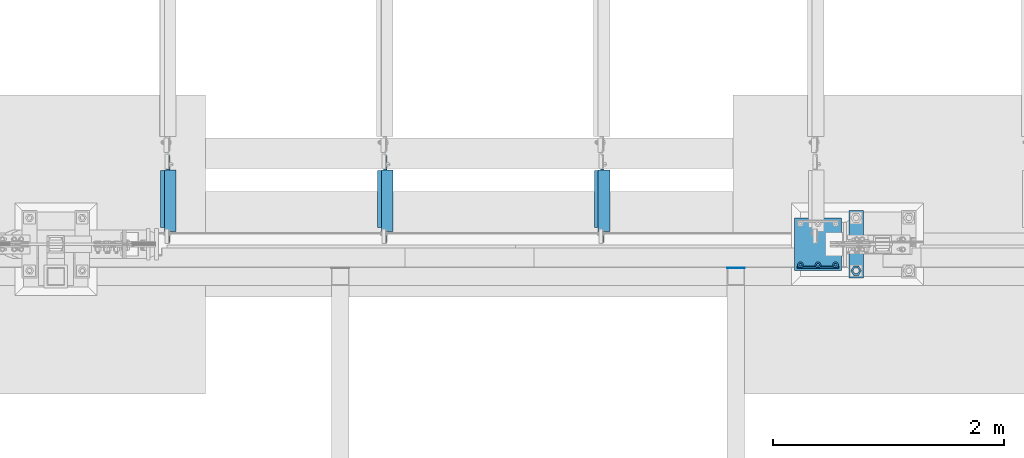
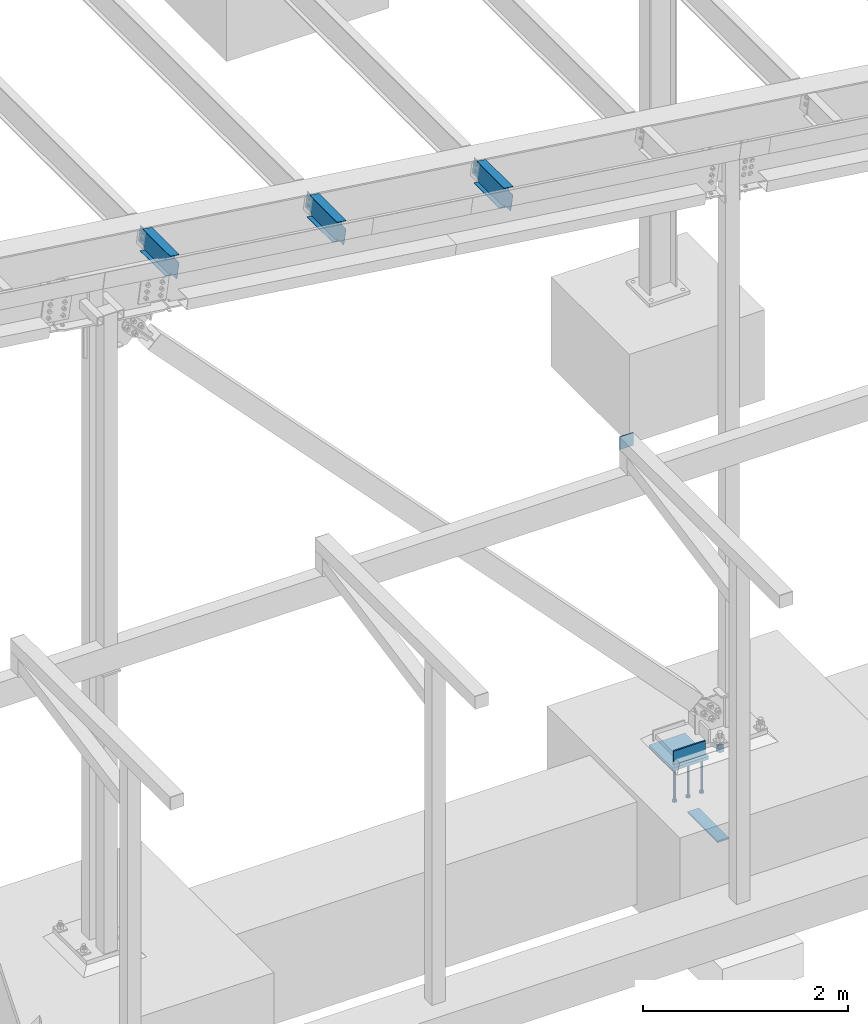
# One storey, part 849 of 1179: 11 beams, 7 elements without a shape of their own.
"""IFC2X3 building model written with IfcOpenShell, lengths in millimetres."""

from ifc_helpers import new_model, si_unit, frame, origin_with_axes, place, context, subcontext, project, spatial, faceted_brep, material, type_object, element, aggregate, save


model = new_model("IFC2X3")

# Units and contexts
model_context = context("Model", 3, precision=1e-05, world=origin_with_axes())
body_context = subcontext(model_context, "Body", "Model", "MODEL_VIEW")
ifc_project = project(units=[si_unit("LENGTHUNIT", "METRE", prefix="MILLI"), si_unit("AREAUNIT", "SQUARE_METRE"), si_unit("VOLUMEUNIT", "CUBIC_METRE"), si_unit("MASSUNIT", "GRAM", prefix="KILO"), si_unit("TIMEUNIT", "SECOND"), si_unit("PLANEANGLEUNIT", "RADIAN"), si_unit("SOLIDANGLEUNIT", "STERADIAN"), si_unit("THERMODYNAMICTEMPERATUREUNIT", "DEGREE_CELSIUS"), si_unit("LUMINOUSINTENSITYUNIT", "LUMEN")], contexts=[model_context])

# Site, building, storey
site_placement = place(None, origin_with_axes())
site = spatial("IfcSite", under=ifc_project, at=site_placement, CompositionType="ELEMENT")
building_placement = place(site_placement, origin_with_axes())
building = spatial("IfcBuilding", under=site, at=building_placement, Name="Undefined", CompositionType="ELEMENT")
storey_placement = place(building_placement, origin_with_axes())
storey = spatial("IfcBuildingStorey", under=building, at=storey_placement, Name="Undefined", CompositionType="ELEMENT", Elevation=0.0)

# Assembly, beam
assembly_1_placement = place(storey_placement, origin_with_axes())
assembly_1 = element("IfcElementAssembly", 1, at=assembly_1_placement, inside=storey, Name="BEAM", AssemblyPlace="NOTDEFINED", PredefinedType="RIGID_FRAME")
ifc_material_1 = material(Name="STEEL/A992")
beam_type_1 = type_object("IfcBeamType", Name="W10X12", PredefinedType="NOTDEFINED")
beam_1_placement = place(assembly_1_placement, frame((32495.2181490509, 4648.2, 6804.55819780635), z_axis=(0.133813223953133, 0.0, 0.991006569652931), x_axis=(0.0, 1.0, 0.0)))
beam_1 = element("IfcBeam", 2, at=beam_1_placement, type_object=beam_type_1, material=ifc_material_1, Name="BEAM", ObjectType="W10X12", context=body_context, shape_type="Brep", body=[
    faceted_brep([(641.349999999998, -2.38124999986758, -120.650000000041), (641.349999999998, -50.7999999998792, -120.650000000054), (641.349999999998, -50.7999999998719, -125.412500000057), (641.349999999998, 50.8000000001484, -125.412500000028), (641.349999999998, 50.8000000001412, -120.650000000027), (641.349999999998, 2.38125000012951, -120.650000000038), (641.349999999998, 2.38125000012224, -106.362499801333), (641.349999999998, -2.38124999988213, -106.362499801329), (642.316729922585, 2.38125000011496, -101.502420283283), (642.316729922585, -2.38124999988213, -101.502420283279), (645.069743823064, 2.38125000011496, -97.3822438151255), (645.069743823064, -2.38124999988941, -97.3822438151219), (649.189920291217, 2.38125000010768, -94.6292299146444), (649.189920291217, -2.38124999989668, -94.6292299146407), (654.049999809263, 2.38125000010768, -93.6624999920532), (654.049999809263, -2.38124999989668, -93.6624999920496), (768.349999999998, -2.38124999988941, -93.6624999919513), (768.349999999998, 2.38125000010768, -93.6624999919441), (109.537500000001, 2.38124999985303, 120.650000000041), (109.537500000001, 50.7999999998647, 120.650000000056), (642.937499999997, 50.7999999998647, 120.650000000056), (642.937499999997, 2.38124999985303, 120.650000000041), (144.462500000001, -2.38124999988213, -106.362499807816), (144.462500000001, 2.38125000011496, -106.362499807819), (144.462500000001, 2.38125000012951, -120.650000000038), (144.462500000001, 50.8000000001412, -120.650000000027), (144.462500000001, 50.8000000001484, -125.412500000028), (144.462500000001, -50.7999999998719, -125.412500000057), (144.462500000001, -50.7999999998792, -120.650000000054), (144.462500000001, -2.38124999986758, -120.650000000041), (143.495770077414, -2.38124999988213, -101.502420289766), (143.495770077414, 2.38125000011496, -101.502420289768), (140.742756176935, -2.38124999988941, -97.3822438216066), (140.742756176935, 2.38125000011496, -97.3822438216102), (136.622579708782, -2.38124999989668, -94.6292299211254), (136.622579708782, 2.38125000010768, -94.6292299211291), (131.762500190736, -2.38124999988941, -93.6624999985379), (131.762500190736, 2.38125000010768, -93.6624999985397), (17.4624999999996, -2.38124999988941, -93.662499998647), (17.4624999999996, 2.38125000010768, -93.6624999986416), (17.4624999999996, -2.38125000011496, 93.6625000015429), (17.4624999999996, 2.38124999988941, 93.6625000015483), (96.8375001907361, -2.38125000011496, 93.662500001652), (96.8375001907361, 2.38124999988941, 93.6625000016502), (101.697579708782, -2.38125000011496, 94.6292299242414), (101.697579708782, 2.38124999987485, 94.6292299242377), (105.817756176935, -2.38125000011496, 97.3822438247225), (105.817756176935, 2.38124999988213, 97.3822438247189), (108.570770077414, -2.38125000012224, 101.50242029288), (108.570770077414, 2.38124999987485, 101.502420292876), (109.537500000001, -2.38125000012951, 106.36249981093), (109.537500000001, 2.38124999986758, 106.362499810928), (109.537500000001, -50.800000000163, 125.412500000028), (109.537500000001, 50.7999999998574, 125.412500000059), (109.537500000001, -2.38125000014406, 120.650000000041), (109.537500000001, -50.8000000001557, 120.650000000027), (642.937499999997, -2.38125000014406, 120.650000000041), (642.937499999997, -50.8000000001557, 120.650000000027), (642.937499999997, -50.800000000163, 125.412500000028), (642.937499999997, 50.7999999998574, 125.412500000059), (642.937499999997, -2.38125000012224, 100.012499817411), (642.937499999997, 2.38124999987485, 100.012499817409), (643.904229922585, -2.38125000012224, 95.1524202993623), (643.904229922585, 2.38124999988213, 95.1524202993587), (646.657243823063, -2.38125000011496, 91.0322438312032), (646.657243823063, 2.38124999988941, 91.0322438311996), (650.777420291217, -2.38125000010768, 88.2792299307239), (650.777420291217, 2.38124999988941, 88.2792299307202), (655.637499809262, -2.38125000010768, 87.3125000081345), (655.637499809262, 2.38124999988941, 87.3125000081309), (768.349999999998, -2.38125000010768, 87.3125000082346), (768.349999999998, 2.38124999988941, 87.31250000824)], [[[0, 1, 2, 3, 4, 5, 6, 7]], [[7, 6, 8, 9]], [[9, 8, 10, 11]], [[11, 10, 12, 13]], [[13, 12, 14, 15]], [[16, 15, 14, 17]], [[18, 19, 20, 21]], [[22, 23, 24, 25, 26, 27, 28, 29]], [[30, 31, 23, 22]], [[32, 33, 31, 30]], [[34, 35, 33, 32]], [[36, 37, 35, 34]], [[38, 39, 37, 36]], [[40, 41, 39, 38]], [[42, 43, 41, 40]], [[44, 45, 43, 42]], [[46, 47, 45, 44]], [[48, 49, 47, 46]], [[50, 51, 49, 48]], [[52, 53, 19, 18, 51, 50, 54, 55]], [[55, 54, 56, 57]], [[52, 55, 57, 58]], [[53, 52, 58, 59]], [[19, 53, 59, 20]], [[58, 57, 56, 60, 61, 21, 20, 59]], [[62, 63, 61, 60]], [[64, 65, 63, 62]], [[66, 67, 65, 64]], [[68, 69, 67, 66]], [[70, 71, 69, 68]], [[71, 70, 16, 17]], [[12, 10, 8, 6, 5, 24, 23, 31, 33, 35, 37, 39, 41, 43, 45, 47, 49, 51, 18, 21, 61, 63, 65, 67, 69, 71, 17, 14]], [[25, 24, 5, 4]], [[26, 25, 4, 3]], [[27, 26, 3, 2]], [[28, 27, 2, 1]], [[29, 28, 1, 0]], [[70, 68, 66, 64, 62, 60, 56, 54, 50, 48, 46, 44, 42, 40, 38, 36, 34, 32, 30, 22, 29, 0, 7, 9, 11, 13, 15, 16]]]),
])
aggregate(assembly_1, [beam_1])

assembly_2_placement = place(storey_placement, origin_with_axes())
assembly_2 = element("IfcElementAssembly", 3, at=assembly_2_placement, inside=storey, Name="BEAM", AssemblyPlace="NOTDEFINED", PredefinedType="RIGID_FRAME")
beam_2_placement = place(assembly_2_placement, frame((30615.6181490507, 4648.2, 7058.35604682428), z_axis=(0.133813223953133, 0.0, 0.991006569652931), x_axis=(0.0, 1.0, 0.0)))
beam_2 = element("IfcBeam", 4, at=beam_2_placement, type_object=beam_type_1, material=ifc_material_1, Name="BEAM", ObjectType="W10X12", context=body_context, shape_type="Brep", body=[
    faceted_brep([(641.349999999998, -2.38124999986758, -120.650000000041), (641.349999999998, -50.7999999998792, -120.650000000054), (641.349999999998, -50.7999999998719, -125.412500000057), (641.349999999998, 50.8000000001484, -125.412500000028), (641.349999999998, 50.8000000001412, -120.650000000027), (641.349999999998, 2.38125000012951, -120.650000000038), (641.349999999998, 2.38125000012224, -106.362499801333), (641.349999999998, -2.38124999988213, -106.362499801329), (642.316729922585, 2.38125000011496, -101.502420283283), (642.316729922585, -2.38124999988213, -101.502420283279), (645.069743823064, 2.38125000011496, -97.3822438151255), (645.069743823064, -2.38124999988941, -97.3822438151219), (649.189920291217, 2.38125000010768, -94.6292299146444), (649.189920291217, -2.38124999989668, -94.6292299146407), (654.049999809263, 2.38125000010768, -93.6624999920532), (654.049999809263, -2.38124999989668, -93.6624999920496), (768.349999999998, -2.38124999988941, -93.6624999919513), (768.349999999998, 2.38125000010768, -93.6624999919441), (109.537500000001, 2.38124999985303, 120.650000000041), (109.537500000001, 50.7999999998647, 120.650000000056), (642.937499999997, 50.7999999998647, 120.650000000056), (642.937499999997, 2.38124999985303, 120.650000000041), (144.462500000001, -2.38124999988213, -106.362499807816), (144.462500000001, 2.38125000011496, -106.362499807819), (144.462500000001, 2.38125000012951, -120.650000000038), (144.462500000001, 50.8000000001412, -120.650000000027), (144.462500000001, 50.8000000001484, -125.412500000028), (144.462500000001, -50.7999999998719, -125.412500000057), (144.462500000001, -50.7999999998792, -120.650000000054), (144.462500000001, -2.38124999986758, -120.650000000041), (143.495770077414, -2.38124999988213, -101.502420289766), (143.495770077414, 2.38125000011496, -101.502420289768), (140.742756176935, -2.38124999988941, -97.3822438216066), (140.742756176935, 2.38125000011496, -97.3822438216102), (136.622579708782, -2.38124999989668, -94.6292299211254), (136.622579708782, 2.38125000010768, -94.6292299211291), (131.762500190736, -2.38124999988941, -93.6624999985379), (131.762500190736, 2.38125000010768, -93.6624999985397), (17.4624999999996, -2.38124999988941, -93.662499998647), (17.4624999999996, 2.38125000010768, -93.6624999986416), (17.4624999999996, -2.38125000011496, 93.6625000015429), (17.4624999999996, 2.38124999988941, 93.6625000015483), (96.8375001907361, -2.38125000011496, 93.662500001652), (96.8375001907361, 2.38124999988941, 93.6625000016502), (101.697579708782, -2.38125000011496, 94.6292299242414), (101.697579708782, 2.38124999987485, 94.6292299242377), (105.817756176935, -2.38125000011496, 97.3822438247225), (105.817756176935, 2.38124999988213, 97.3822438247189), (108.570770077414, -2.38125000012224, 101.50242029288), (108.570770077414, 2.38124999987485, 101.502420292876), (109.537500000001, -2.38125000012951, 106.36249981093), (109.537500000001, 2.38124999986758, 106.362499810928), (109.537500000001, -50.800000000163, 125.412500000028), (109.537500000001, 50.7999999998574, 125.412500000059), (109.537500000001, -2.38125000014406, 120.650000000041), (109.537500000001, -50.8000000001557, 120.650000000027), (642.937499999997, -2.38125000014406, 120.650000000041), (642.937499999997, -50.8000000001557, 120.650000000027), (642.937499999997, -50.800000000163, 125.412500000028), (642.937499999997, 50.7999999998574, 125.412500000059), (642.937499999997, -2.38125000012224, 100.012499817411), (642.937499999997, 2.38124999987485, 100.012499817409), (643.904229922585, -2.38125000012224, 95.1524202993623), (643.904229922585, 2.38124999988213, 95.1524202993587), (646.657243823063, -2.38125000011496, 91.0322438312032), (646.657243823063, 2.38124999988941, 91.0322438311996), (650.777420291217, -2.38125000010768, 88.2792299307239), (650.777420291217, 2.38124999988941, 88.2792299307202), (655.637499809262, -2.38125000010768, 87.3125000081345), (655.637499809262, 2.38124999988941, 87.3125000081309), (768.349999999998, -2.38125000010768, 87.3125000082346), (768.349999999998, 2.38124999988941, 87.31250000824)], [[[0, 1, 2, 3, 4, 5, 6, 7]], [[7, 6, 8, 9]], [[9, 8, 10, 11]], [[11, 10, 12, 13]], [[13, 12, 14, 15]], [[16, 15, 14, 17]], [[18, 19, 20, 21]], [[22, 23, 24, 25, 26, 27, 28, 29]], [[30, 31, 23, 22]], [[32, 33, 31, 30]], [[34, 35, 33, 32]], [[36, 37, 35, 34]], [[38, 39, 37, 36]], [[40, 41, 39, 38]], [[42, 43, 41, 40]], [[44, 45, 43, 42]], [[46, 47, 45, 44]], [[48, 49, 47, 46]], [[50, 51, 49, 48]], [[52, 53, 19, 18, 51, 50, 54, 55]], [[55, 54, 56, 57]], [[52, 55, 57, 58]], [[53, 52, 58, 59]], [[19, 53, 59, 20]], [[58, 57, 56, 60, 61, 21, 20, 59]], [[62, 63, 61, 60]], [[64, 65, 63, 62]], [[66, 67, 65, 64]], [[68, 69, 67, 66]], [[70, 71, 69, 68]], [[71, 70, 16, 17]], [[12, 10, 8, 6, 5, 24, 23, 31, 33, 35, 37, 39, 41, 43, 45, 47, 49, 51, 18, 21, 61, 63, 65, 67, 69, 71, 17, 14]], [[25, 24, 5, 4]], [[26, 25, 4, 3]], [[27, 26, 3, 2]], [[28, 27, 2, 1]], [[29, 28, 1, 0]], [[70, 68, 66, 64, 62, 60, 56, 54, 50, 48, 46, 44, 42, 40, 38, 36, 34, 32, 30, 22, 29, 0, 7, 9, 11, 13, 15, 16]]]),
])
aggregate(assembly_2, [beam_2])

assembly_3_placement = place(storey_placement, origin_with_axes())
assembly_3 = element("IfcElementAssembly", 5, at=assembly_3_placement, inside=storey, Name="BEAM", AssemblyPlace="NOTDEFINED", PredefinedType="RIGID_FRAME")
beam_3_placement = place(assembly_3_placement, frame((28736.0181490507, 4648.2, 7312.15389584228), z_axis=(0.133813223953133, 0.0, 0.991006569652931), x_axis=(0.0, 1.0, 0.0)))
beam_3 = element("IfcBeam", 6, at=beam_3_placement, type_object=beam_type_1, material=ifc_material_1, Name="BEAM", ObjectType="W10X12", context=body_context, shape_type="Brep", body=[
    faceted_brep([(641.349999999998, -2.38124999986758, -120.650000000041), (641.349999999998, -50.7999999998792, -120.650000000054), (641.349999999998, -50.7999999998719, -125.412500000057), (641.349999999998, 50.8000000001484, -125.412500000028), (641.349999999998, 50.8000000001412, -120.650000000027), (641.349999999998, 2.38125000012951, -120.650000000038), (641.349999999998, 2.38125000012224, -106.362499801333), (641.349999999998, -2.38124999988213, -106.362499801329), (642.316729922585, 2.38125000011496, -101.502420283283), (642.316729922585, -2.38124999988213, -101.502420283279), (645.069743823064, 2.38125000011496, -97.3822438151255), (645.069743823064, -2.38124999988941, -97.3822438151219), (649.189920291217, 2.38125000010768, -94.6292299146444), (649.189920291217, -2.38124999989668, -94.6292299146407), (654.049999809263, 2.38125000010768, -93.6624999920532), (654.049999809263, -2.38124999989668, -93.6624999920496), (768.349999999998, -2.38124999988941, -93.6624999919513), (768.349999999998, 2.38125000010768, -93.6624999919441), (109.537500000001, 2.38124999985303, 120.650000000041), (109.537500000001, 50.7999999998647, 120.650000000056), (642.937499999997, 50.7999999998647, 120.650000000056), (642.937499999997, 2.38124999985303, 120.650000000041), (144.462500000001, -2.38124999988213, -106.362499807816), (144.462500000001, 2.38125000011496, -106.362499807819), (144.462500000001, 2.38125000012951, -120.650000000038), (144.462500000001, 50.8000000001412, -120.650000000027), (144.462500000001, 50.8000000001484, -125.412500000028), (144.462500000001, -50.7999999998719, -125.412500000057), (144.462500000001, -50.7999999998792, -120.650000000054), (144.462500000001, -2.38124999986758, -120.650000000041), (143.495770077414, -2.38124999988213, -101.502420289766), (143.495770077414, 2.38125000011496, -101.502420289768), (140.742756176935, -2.38124999988941, -97.3822438216066), (140.742756176935, 2.38125000011496, -97.3822438216102), (136.622579708782, -2.38124999989668, -94.6292299211254), (136.622579708782, 2.38125000010768, -94.6292299211291), (131.762500190736, -2.38124999988941, -93.6624999985379), (131.762500190736, 2.38125000010768, -93.6624999985397), (17.4624999999996, -2.38124999988941, -93.662499998647), (17.4624999999996, 2.38125000010768, -93.6624999986416), (17.4624999999996, -2.38125000011496, 93.6625000015429), (17.4624999999996, 2.38124999988941, 93.6625000015483), (96.8375001907361, -2.38125000011496, 93.662500001652), (96.8375001907361, 2.38124999988941, 93.6625000016502), (101.697579708782, -2.38125000011496, 94.6292299242414), (101.697579708782, 2.38124999987485, 94.6292299242377), (105.817756176935, -2.38125000011496, 97.3822438247225), (105.817756176935, 2.38124999988213, 97.3822438247189), (108.570770077414, -2.38125000012224, 101.50242029288), (108.570770077414, 2.38124999987485, 101.502420292876), (109.537500000001, -2.38125000012951, 106.36249981093), (109.537500000001, 2.38124999986758, 106.362499810928), (109.537500000001, -50.800000000163, 125.412500000028), (109.537500000001, 50.7999999998574, 125.412500000059), (109.537500000001, -2.38125000014406, 120.650000000041), (109.537500000001, -50.8000000001557, 120.650000000027), (642.937499999997, -2.38125000014406, 120.650000000041), (642.937499999997, -50.8000000001557, 120.650000000027), (642.937499999997, -50.800000000163, 125.412500000028), (642.937499999997, 50.7999999998574, 125.412500000059), (642.937499999997, -2.38125000012224, 100.012499817411), (642.937499999997, 2.38124999987485, 100.012499817409), (643.904229922585, -2.38125000012224, 95.1524202993623), (643.904229922585, 2.38124999988213, 95.1524202993587), (646.657243823063, -2.38125000011496, 91.0322438312032), (646.657243823063, 2.38124999988941, 91.0322438311996), (650.777420291217, -2.38125000010768, 88.2792299307239), (650.777420291217, 2.38124999988941, 88.2792299307202), (655.637499809262, -2.38125000010768, 87.3125000081345), (655.637499809262, 2.38124999988941, 87.3125000081309), (768.349999999998, -2.38125000010768, 87.3125000082346), (768.349999999998, 2.38124999988941, 87.31250000824)], [[[0, 1, 2, 3, 4, 5, 6, 7]], [[7, 6, 8, 9]], [[9, 8, 10, 11]], [[11, 10, 12, 13]], [[13, 12, 14, 15]], [[16, 15, 14, 17]], [[18, 19, 20, 21]], [[22, 23, 24, 25, 26, 27, 28, 29]], [[30, 31, 23, 22]], [[32, 33, 31, 30]], [[34, 35, 33, 32]], [[36, 37, 35, 34]], [[38, 39, 37, 36]], [[40, 41, 39, 38]], [[42, 43, 41, 40]], [[44, 45, 43, 42]], [[46, 47, 45, 44]], [[48, 49, 47, 46]], [[50, 51, 49, 48]], [[52, 53, 19, 18, 51, 50, 54, 55]], [[55, 54, 56, 57]], [[52, 55, 57, 58]], [[53, 52, 58, 59]], [[19, 53, 59, 20]], [[58, 57, 56, 60, 61, 21, 20, 59]], [[62, 63, 61, 60]], [[64, 65, 63, 62]], [[66, 67, 65, 64]], [[68, 69, 67, 66]], [[70, 71, 69, 68]], [[71, 70, 16, 17]], [[12, 10, 8, 6, 5, 24, 23, 31, 33, 35, 37, 39, 41, 43, 45, 47, 49, 51, 18, 21, 61, 63, 65, 67, 69, 71, 17, 14]], [[25, 24, 5, 4]], [[26, 25, 4, 3]], [[27, 26, 3, 2]], [[28, 27, 2, 1]], [[29, 28, 1, 0]], [[70, 68, 66, 64, 62, 60, 56, 54, 50, 48, 46, 44, 42, 40, 38, 36, 34, 32, 30, 22, 29, 0, 7, 9, 11, 13, 15, 16]]]),
])
aggregate(assembly_3, [beam_3])

assembly_4_placement = place(storey_placement, origin_with_axes())
assembly_4 = element("IfcElementAssembly", 7, at=assembly_4_placement, inside=storey, Name="BEAM", AssemblyPlace="NOTDEFINED", PredefinedType="RIGID_FRAME")
ifc_material_2 = material(Name="STEEL/A36")
beam_type_2 = type_object("IfcBeamType", PredefinedType="NOTDEFINED")
beam_4_placement = place(assembly_4_placement, frame((33731.2, 4441.825, 3702.05), z_axis=(0.0, 0.0, -1.0), x_axis=(-1.0, 0.0, 0.0)))
beam_4 = element("IfcBeam", 8, at=beam_4_placement, type_object=beam_type_2, material=ifc_material_2, Name="PLATE", context=body_context, shape_type="Brep", body=[
    faceted_brep([(-1.47792889038101e-12, 3.17500000000018, -76.1999999999953), (1.36424205265939e-12, 3.17500000000018, 76.1999999999953), (152.399999999989, 3.17500000000018, 76.200000000028), (152.399999999986, 3.17500000000018, -76.1999999999625), (1.36424205265939e-12, -3.17500000000018, 76.1999999999953), (152.399999999989, -3.17500000000018, 76.200000000028), (-1.47792889038101e-12, -3.17500000000018, -76.1999999999953), (152.399999999986, -3.17500000000018, -76.1999999999625)], [[[0, 1, 2, 3]], [[1, 4, 5, 2]], [[4, 6, 7, 5]], [[6, 0, 3, 7]], [[5, 7, 3, 2]], [[6, 4, 1, 0]]]),
])
aggregate(assembly_4, [beam_4])

# Assembly, beams
assembly_5_placement = place(storey_placement, origin_with_axes())
assembly_5 = element("IfcElementAssembly", 9, at=assembly_5_placement, inside=storey, Name="TEMPLATE", AssemblyPlace="NOTDEFINED", PredefinedType="RIGID_FRAME")
beam_type_3 = type_object("IfcBeamType", PredefinedType="NOTDEFINED")
beam_5_placement = place(assembly_5_placement, frame((34696.3999938965, 4940.30001220703, -1362.075), z_axis=(1.0, 0.0, 0.0), x_axis=(0.0, -1.0, 0.0)))
beam_5 = element("IfcBeam", 10, at=beam_5_placement, type_object=beam_type_3, material=ifc_material_2, Name="SQ WASHER", context=body_context, shape_type="Brep", body=[
    faceted_brep([(0.0, 9.52500000000146, -63.5), (0.0, 9.52500000000146, 63.5), (584.199999999997, 9.52500000000009, 63.5), (584.199999999997, 9.52500000000009, -63.5), (0.0, -9.52500000000146, 63.5), (584.199999999997, -9.52500000000009, 63.5), (0.0, -9.52500000000146, -63.5), (584.199999999997, -9.52500000000009, -63.5)], [[[0, 1, 2, 3]], [[1, 4, 5, 2]], [[4, 6, 7, 5]], [[6, 0, 3, 7]], [[5, 7, 3, 2]], [[6, 4, 1, 0]]]),
])
beam_type_4 = type_object("IfcBeamType", Name="2_HEAVY_HEX_NUT", PredefinedType="NOTDEFINED")
beam_6_placement = place(assembly_5_placement, frame((34696.400012207, 4419.6, -279.4), z_axis=(0.0, -1.0, 0.0), x_axis=(0.0, 0.0, -1.0)))
beam_6 = element("IfcBeam", 11, at=beam_6_placement, type_object=beam_type_4, material=ifc_material_2, Name="NUT", ObjectType="2_HEAVY_HEX_NUT", context=body_context, shape_type="Brep", body=[
    faceted_brep([(0.0, -46.0369987487793, 9.09494701772928e-13), (0.0, -23.0184993743896, -39.869213104248), (50.7999999999993, -23.0184993743896, -39.869213104248), (50.7999999999993, -46.0369987487793, 9.09494701772928e-13), (0.0, 23.0184993743896, -39.869213104248), (50.7999999999993, 23.0184993743896, -39.869213104248), (0.0, 46.0369987487793, -9.09494701772928e-13), (50.7999999999993, 46.0369987487793, -9.09494701772928e-13), (0.0, 23.0184993743896, 39.869213104248), (50.7999999999993, 23.0184993743896, 39.869213104248), (0.0, -23.0184993743896, 39.869213104248), (50.7999999999993, -23.0184993743896, 39.869213104248), (0.0, 0.0, 26.1940002441406), (0.0, 11.3650617044477, 23.5999013092769), (50.7999999999993, 11.3650617044477, 23.5999013092769), (50.7999999999993, 0.0, 26.1940002441406), (0.0, 20.4791109456419, 16.3316083006703), (50.7999999999993, 20.4791109456419, 16.3316083006703), (0.0, 25.5370200498364, 5.82867859874477), (50.7999999999993, 25.5370200498364, 5.82867859874477), (0.0, 25.5370200498364, -5.82867859874477), (50.7999999999993, 25.5370200498364, -5.82867859874477), (0.0, 20.4791109456419, -16.3316083006703), (50.7999999999993, 20.4791109456419, -16.3316083006703), (0.0, 11.365061704455, -23.5999013092769), (50.7999999999993, 11.365061704455, -23.5999013092769), (0.0, 0.0, -26.1940002441406), (50.7999999999993, 0.0, -26.1940002441406), (0.0, -11.3650617044477, -23.5999013092769), (50.7999999999993, -11.3650617044477, -23.5999013092769), (0.0, -20.4791109456419, -16.3316083006703), (50.7999999999993, -20.4791109456419, -16.3316083006703), (0.0, -25.5370200498364, -5.82867859874477), (50.7999999999993, -25.5370200498364, -5.82867859874477), (0.0, -25.5370200498364, 5.82867859874477), (50.7999999999993, -25.5370200498364, 5.82867859874477), (0.0, -20.4791109456419, 16.3316083006703), (50.7999999999993, -20.4791109456419, 16.3316083006703), (0.0, -11.365061704455, 23.5999013092769), (50.7999999999993, -11.365061704455, 23.5999013092769)], [[[0, 1, 2, 3]], [[1, 4, 5, 2]], [[4, 6, 7, 5]], [[6, 8, 9, 7]], [[8, 10, 11, 9]], [[10, 0, 3, 11]], [[12, 13, 14, 15]], [[13, 16, 17, 14]], [[16, 18, 19, 17]], [[18, 20, 21, 19]], [[20, 22, 23, 21]], [[22, 24, 25, 23]], [[24, 26, 27, 25]], [[26, 28, 29, 27]], [[28, 30, 31, 29]], [[30, 32, 33, 31]], [[32, 34, 35, 33]], [[34, 36, 37, 35]], [[36, 38, 39, 37]], [[38, 12, 15, 39]], [[5, 7, 9, 11, 3, 2], [17, 19, 21, 23, 25, 27, 29, 31, 33, 35, 37, 39, 15, 14]], [[10, 8, 6, 4, 1, 0], [38, 36, 34, 32, 30, 28, 26, 24, 22, 20, 18, 16, 13, 12]]]),
])
aggregate(assembly_5, [beam_6, beam_5])

# Assembly, beam
assembly_6_placement = place(storey_placement, origin_with_axes())
assembly_6 = element("IfcElementAssembly", 12, at=assembly_6_placement, inside=storey, Name="PLATE", AssemblyPlace="NOTDEFINED", PredefinedType="RIGID_FRAME")
ifc_material_3 = material(Name="STEEL/A572-GR.50")
beam_type_5 = type_object("IfcBeamType", PredefinedType="NOTDEFINED")
beam_7_placement = place(assembly_6_placement, frame((34543.9999993009, 4449.7624984737, -266.7), z_axis=(0.0, 0.0, 1.0), x_axis=(-1.0, 0.0, 0.0)))
beam_7 = element("IfcBeam", 13, at=beam_7_placement, type_object=beam_type_5, material=ifc_material_3, Name="PLATE", context=body_context, shape_type="Brep", body=[
    faceted_brep([(355.599999999999, 7.9375, -73.025), (355.599999999999, -7.9375, -88.9), (0.0, -7.9375, -88.9), (0.0, 7.9375, -73.025), (0.0, 7.9375, 88.9), (355.599999999999, 7.9375, 88.9), (0.0, -7.9375, 88.9), (355.599999999999, -7.9375, 88.9)], [[[0, 1, 2, 3]], [[4, 5, 0, 3]], [[4, 6, 7, 5]], [[6, 2, 1, 7]], [[5, 7, 1, 0]], [[6, 4, 3, 2]]]),
])
aggregate(assembly_6, [beam_7])

# Assembly, beams
assembly_7_placement = place(storey_placement, origin_with_axes())
assembly_7 = element("IfcElementAssembly", 14, at=assembly_7_placement, inside=storey, Name="EMBED_PLATE", AssemblyPlace="NOTDEFINED", PredefinedType="RIGID_FRAME")
ifc_material_4 = material(Name="STEEL/A108")
beam_type_6 = type_object("IfcBeamType", Name="STUD_1-DIA", PredefinedType="NOTDEFINED")
beam_8_placement = place(assembly_7_placement, frame((34518.6, 4470.4, -393.7), z_axis=(-1.0, 0.0, 0.0), x_axis=(0.0, 0.0, -1.0)))
beam_8 = element("IfcBeam", 15, at=beam_8_placement, type_object=beam_type_6, material=ifc_material_4, Name="STUD", ObjectType="STUD_1-DIA", context=body_context, shape_type="Brep", body=[
    faceted_brep([(0.0, -12.7, 0.0), (0.0, -11.0, -6.34999990463257), (382.016, -11.0, -6.34999990463257), (382.016, -12.6999998092651, 0.0), (0.0, -6.34999990463257, -11.0), (382.016, -6.34999990463257, -11.0), (0.0, 0.0, -12.6999998092651), (382.016, 0.0, -12.6999998092651), (0.0, 6.34999990463257, -11.0), (382.016, 6.34999990463257, -11.0), (0.0, 11.0, -6.34999990463257), (382.016, 11.0, -6.34999990463257), (0.0, 12.7, 0.0), (382.016, 12.6999998092651, 0.0), (0.0, 11.0, 6.34999990463257), (382.016, 11.0, 6.34999990463257), (0.0, 6.34999990463257, 11.0), (382.016, 6.34999990463257, 11.0), (0.0, 0.0, 12.6999998092651), (382.016, 0.0, 12.6999998092651), (0.0, -6.34999990463257, 11.0), (382.016, -6.34999990463257, 11.0), (0.0, -11.0, 6.34999990463257), (382.016, -11.0, 6.34999990463257), (386.08, -22.0, -12.6999998092651), (386.08, -25.3999996185303, 0.0), (386.08, -12.6999998092651, -22.0), (386.08, 0.0, -25.3999996185303), (386.08, 12.6999998092651, -22.0), (386.08, 22.0, -12.6999998092651), (386.08, 25.3999996185303, 0.0), (386.08, 22.0, 12.6999998092651), (386.08, 12.6999998092651, 22.0), (386.08, 0.0, 25.3999996185303), (386.08, -12.6999998092651, 22.0), (386.08, -22.0, 12.6999998092651), (406.4, -22.0, -12.6999998092651), (406.4, -25.3999996185303, 0.0), (406.4, -12.6999998092651, -22.0), (406.4, 0.0, -25.3999996185303), (406.4, 12.6999998092651, -22.0), (406.4, 22.0, -12.6999998092651), (406.4, 25.3999996185303, 0.0), (406.4, 22.0, 12.6999998092651), (406.4, 12.6999998092651, 22.0), (406.4, 0.0, 25.3999996185303), (406.4, -12.6999998092651, 22.0), (406.4, -22.0, 12.6999998092651)], [[[0, 1, 2, 3]], [[1, 4, 5, 2]], [[4, 6, 7, 5]], [[6, 8, 9, 7]], [[8, 10, 11, 9]], [[10, 12, 13, 11]], [[12, 14, 15, 13]], [[14, 16, 17, 15]], [[16, 18, 19, 17]], [[18, 20, 21, 19]], [[20, 22, 23, 21]], [[22, 0, 3, 23]], [[22, 20, 18, 16, 14, 12, 10, 8, 6, 4, 1, 0]], [[3, 2, 24, 25]], [[2, 5, 26, 24]], [[5, 7, 27, 26]], [[7, 9, 28, 27]], [[9, 11, 29, 28]], [[11, 13, 30, 29]], [[13, 15, 31, 30]], [[15, 17, 32, 31]], [[17, 19, 33, 32]], [[19, 21, 34, 33]], [[21, 23, 35, 34]], [[23, 3, 25, 35]], [[25, 24, 36, 37]], [[24, 26, 38, 36]], [[26, 27, 39, 38]], [[27, 28, 40, 39]], [[28, 29, 41, 40]], [[29, 30, 42, 41]], [[30, 31, 43, 42]], [[31, 32, 44, 43]], [[32, 33, 45, 44]], [[33, 34, 46, 45]], [[34, 35, 47, 46]], [[35, 25, 37, 47]], [[38, 39, 40, 41, 42, 43, 44, 45, 46, 47, 37, 36]]]),
])
beam_9_placement = place(assembly_7_placement, frame((34213.8, 4470.4, -393.7), z_axis=(-1.0, 0.0, 0.0), x_axis=(0.0, 0.0, -1.0)))
beam_9 = element("IfcBeam", 16, at=beam_9_placement, type_object=beam_type_6, material=ifc_material_4, Name="STUD", ObjectType="STUD_1-DIA", context=body_context, shape_type="Brep", body=[
    faceted_brep([(0.0, -12.7, 0.0), (0.0, -11.0, -6.34999990463257), (382.016, -11.0, -6.34999990463257), (382.016, -12.6999998092651, 0.0), (0.0, -6.34999990463257, -11.0), (382.016, -6.34999990463257, -11.0), (0.0, 0.0, -12.6999998092651), (382.016, 0.0, -12.6999998092651), (0.0, 6.34999990463257, -11.0), (382.016, 6.34999990463257, -11.0), (0.0, 11.0, -6.34999990463257), (382.016, 11.0, -6.34999990463257), (0.0, 12.7, 0.0), (382.016, 12.6999998092651, 0.0), (0.0, 11.0, 6.34999990463257), (382.016, 11.0, 6.34999990463257), (0.0, 6.34999990463257, 11.0), (382.016, 6.34999990463257, 11.0), (0.0, 0.0, 12.6999998092651), (382.016, 0.0, 12.6999998092651), (0.0, -6.34999990463257, 11.0), (382.016, -6.34999990463257, 11.0), (0.0, -11.0, 6.34999990463257), (382.016, -11.0, 6.34999990463257), (386.08, -22.0, -12.6999998092651), (386.08, -25.3999996185303, 0.0), (386.08, -12.6999998092651, -22.0), (386.08, 0.0, -25.3999996185303), (386.08, 12.6999998092651, -22.0), (386.08, 22.0, -12.6999998092651), (386.08, 25.3999996185303, 0.0), (386.08, 22.0, 12.6999998092651), (386.08, 12.6999998092651, 22.0), (386.08, 0.0, 25.3999996185303), (386.08, -12.6999998092651, 22.0), (386.08, -22.0, 12.6999998092651), (406.4, -22.0, -12.6999998092651), (406.4, -25.3999996185303, 0.0), (406.4, -12.6999998092651, -22.0), (406.4, 0.0, -25.3999996185303), (406.4, 12.6999998092651, -22.0), (406.4, 22.0, -12.6999998092651), (406.4, 25.3999996185303, 0.0), (406.4, 22.0, 12.6999998092651), (406.4, 12.6999998092651, 22.0), (406.4, 0.0, 25.3999996185303), (406.4, -12.6999998092651, 22.0), (406.4, -22.0, 12.6999998092651)], [[[0, 1, 2, 3]], [[1, 4, 5, 2]], [[4, 6, 7, 5]], [[6, 8, 9, 7]], [[8, 10, 11, 9]], [[10, 12, 13, 11]], [[12, 14, 15, 13]], [[14, 16, 17, 15]], [[16, 18, 19, 17]], [[18, 20, 21, 19]], [[20, 22, 23, 21]], [[22, 0, 3, 23]], [[22, 20, 18, 16, 14, 12, 10, 8, 6, 4, 1, 0]], [[3, 2, 24, 25]], [[2, 5, 26, 24]], [[5, 7, 27, 26]], [[7, 9, 28, 27]], [[9, 11, 29, 28]], [[11, 13, 30, 29]], [[13, 15, 31, 30]], [[15, 17, 32, 31]], [[17, 19, 33, 32]], [[19, 21, 34, 33]], [[21, 23, 35, 34]], [[23, 3, 25, 35]], [[25, 24, 36, 37]], [[24, 26, 38, 36]], [[26, 27, 39, 38]], [[27, 28, 40, 39]], [[28, 29, 41, 40]], [[29, 30, 42, 41]], [[30, 31, 43, 42]], [[31, 32, 44, 43]], [[32, 33, 45, 44]], [[33, 34, 46, 45]], [[34, 35, 47, 46]], [[35, 25, 37, 47]], [[38, 39, 40, 41, 42, 43, 44, 45, 46, 47, 37, 36]]]),
])
beam_10_placement = place(assembly_7_placement, frame((34366.2, 4470.4, -393.7), z_axis=(-1.0, 0.0, 0.0), x_axis=(0.0, 0.0, -1.0)))
beam_10 = element("IfcBeam", 17, at=beam_10_placement, type_object=beam_type_6, material=ifc_material_4, Name="STUD", ObjectType="STUD_1-DIA", context=body_context, shape_type="Brep", body=[
    faceted_brep([(0.0, -12.7, 0.0), (0.0, -11.0, -6.34999990463257), (382.016, -11.0, -6.34999990463257), (382.016, -12.6999998092651, 0.0), (0.0, -6.34999990463257, -11.0), (382.016, -6.34999990463257, -11.0), (0.0, 0.0, -12.6999998092651), (382.016, 0.0, -12.6999998092651), (0.0, 6.34999990463257, -11.0), (382.016, 6.34999990463257, -11.0), (0.0, 11.0, -6.34999990463257), (382.016, 11.0, -6.34999990463257), (0.0, 12.7, 0.0), (382.016, 12.6999998092651, 0.0), (0.0, 11.0, 6.34999990463257), (382.016, 11.0, 6.34999990463257), (0.0, 6.34999990463257, 11.0), (382.016, 6.34999990463257, 11.0), (0.0, 0.0, 12.6999998092651), (382.016, 0.0, 12.6999998092651), (0.0, -6.34999990463257, 11.0), (382.016, -6.34999990463257, 11.0), (0.0, -11.0, 6.34999990463257), (382.016, -11.0, 6.34999990463257), (386.08, -22.0, -12.6999998092651), (386.08, -25.3999996185303, 0.0), (386.08, -12.6999998092651, -22.0), (386.08, 0.0, -25.3999996185303), (386.08, 12.6999998092651, -22.0), (386.08, 22.0, -12.6999998092651), (386.08, 25.3999996185303, 0.0), (386.08, 22.0, 12.6999998092651), (386.08, 12.6999998092651, 22.0), (386.08, 0.0, 25.3999996185303), (386.08, -12.6999998092651, 22.0), (386.08, -22.0, 12.6999998092651), (406.4, -22.0, -12.6999998092651), (406.4, -25.3999996185303, 0.0), (406.4, -12.6999998092651, -22.0), (406.4, 0.0, -25.3999996185303), (406.4, 12.6999998092651, -22.0), (406.4, 22.0, -12.6999998092651), (406.4, 25.3999996185303, 0.0), (406.4, 22.0, 12.6999998092651), (406.4, 12.6999998092651, 22.0), (406.4, 0.0, 25.3999996185303), (406.4, -12.6999998092651, 22.0), (406.4, -22.0, 12.6999998092651)], [[[0, 1, 2, 3]], [[1, 4, 5, 2]], [[4, 6, 7, 5]], [[6, 8, 9, 7]], [[8, 10, 11, 9]], [[10, 12, 13, 11]], [[12, 14, 15, 13]], [[14, 16, 17, 15]], [[16, 18, 19, 17]], [[18, 20, 21, 19]], [[20, 22, 23, 21]], [[22, 0, 3, 23]], [[22, 20, 18, 16, 14, 12, 10, 8, 6, 4, 1, 0]], [[3, 2, 24, 25]], [[2, 5, 26, 24]], [[5, 7, 27, 26]], [[7, 9, 28, 27]], [[9, 11, 29, 28]], [[11, 13, 30, 29]], [[13, 15, 31, 30]], [[15, 17, 32, 31]], [[17, 19, 33, 32]], [[19, 21, 34, 33]], [[21, 23, 35, 34]], [[23, 3, 25, 35]], [[25, 24, 36, 37]], [[24, 26, 38, 36]], [[26, 27, 39, 38]], [[27, 28, 40, 39]], [[28, 29, 41, 40]], [[29, 30, 42, 41]], [[30, 31, 43, 42]], [[31, 32, 44, 43]], [[32, 33, 45, 44]], [[33, 34, 46, 45]], [[34, 35, 47, 46]], [[35, 25, 37, 47]], [[38, 39, 40, 41, 42, 43, 44, 45, 46, 47, 37, 36]]]),
])
beam_type_7 = type_object("IfcBeamType", PredefinedType="NOTDEFINED")
beam_11_placement = place(assembly_7_placement, frame((34569.4, 4648.2, -374.65), z_axis=(0.0, -1.0, 0.0), x_axis=(-1.0, 0.0, 0.0)))
beam_11 = element("IfcBeam", 18, at=beam_11_placement, type_object=beam_type_7, material=ifc_material_3, Name="EMBED_PLATE", context=body_context, shape_type="Brep", body=[
    faceted_brep([(0.0, 19.05, -228.6), (0.0, 19.05, 228.6), (406.400000000001, 19.05, 228.6), (406.400000000001, 19.05, -228.6), (0.0, -19.05, 228.6), (406.400000000001, -19.05, 228.6), (0.0, -19.05, -228.6), (406.400000000001, -19.05, -228.6)], [[[0, 1, 2, 3]], [[1, 4, 5, 2]], [[4, 6, 7, 5]], [[6, 0, 3, 7]], [[5, 7, 3, 2]], [[6, 4, 1, 0]]]),
])
aggregate(assembly_7, [beam_8, beam_9, beam_10, beam_11])

save(model, "model.ifc")
